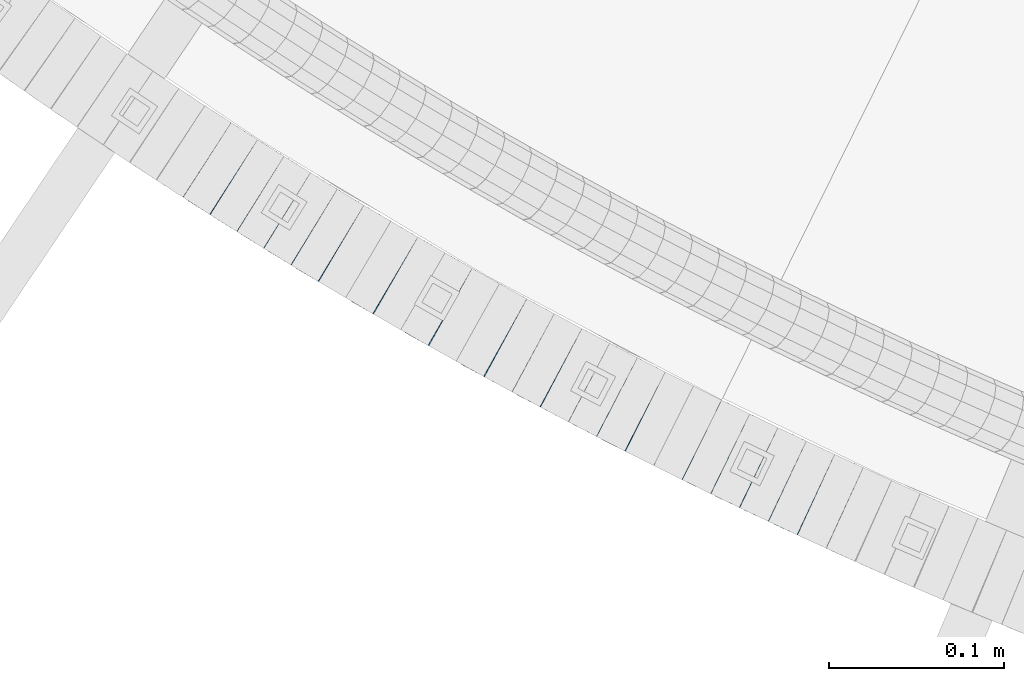
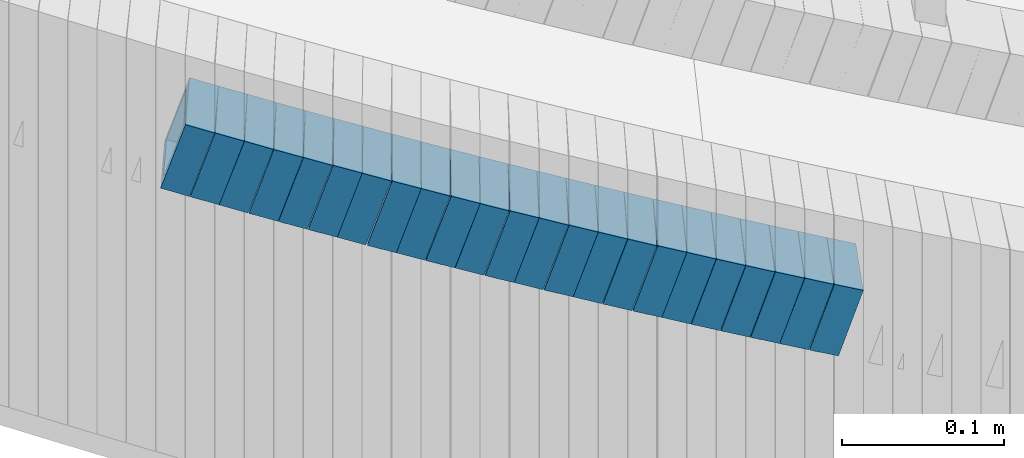
# One storey, part 650 of 975: 23 beams.
"""IFC2X3 building model written with IfcOpenShell, lengths in millimetres."""

from ifc_helpers import new_model, si_unit, frame, origin_with_axes, place, context, subcontext, project, spatial, faceted_brep, material, type_object, element, save


model = new_model("IFC2X3")

# Units and contexts
model_context = context("Model", 3, precision=1e-05, world=origin_with_axes())
body_context = subcontext(model_context, "Body", "Model", "MODEL_VIEW")
ifc_project = project(units=[si_unit("LENGTHUNIT", "METRE", prefix="MILLI"), si_unit("AREAUNIT", "SQUARE_METRE"), si_unit("VOLUMEUNIT", "CUBIC_METRE"), si_unit("MASSUNIT", "GRAM", prefix="KILO"), si_unit("TIMEUNIT", "SECOND"), si_unit("PLANEANGLEUNIT", "RADIAN"), si_unit("SOLIDANGLEUNIT", "STERADIAN"), si_unit("THERMODYNAMICTEMPERATUREUNIT", "DEGREE_CELSIUS"), si_unit("LUMINOUSINTENSITYUNIT", "LUMEN")], contexts=[model_context])

# Site, building, storey
site_placement = place(None, origin_with_axes())
site = spatial("IfcSite", under=ifc_project, at=site_placement, CompositionType="ELEMENT")
building_placement = place(site_placement, origin_with_axes())
building = spatial("IfcBuilding", under=site, at=building_placement, Name="Undefined", CompositionType="ELEMENT")
storey_placement = place(building_placement, origin_with_axes())
storey = spatial("IfcBuildingStorey", under=building, at=storey_placement, Name="Undefined", CompositionType="ELEMENT", Elevation=0.0)

# Beams
ifc_material = material()
beam_type = type_object("IfcBeamType", Name="HSS2X2X.188_TUBES", PredefinedType="NOTDEFINED")
beam_1_placement = place(storey_placement, frame((33173.8682936073, 994.158884126241, 3812.79161391269), z_axis=(0.540475947434613, 0.841359465534594, 2.42845999309793e-10), x_axis=(0.801887983873105, -0.515120094918474, -0.302699436952085)))
element("IfcBeam", 1, at=beam_1_placement, inside=storey, type_object=beam_type, material=ifc_material, Name="WALL", ObjectType="HSS2X2X.188_TUBES", context=body_context, shape_type="Brep", body=[
    faceted_brep([(0.0, 20.6374999999753, -20.6375000000298), (0.0, -20.6375000000153, -20.6375000000153), (18.8332159191086, -20.6374999999916, -20.6375000000153), (18.8332159190923, 20.6375000000062, -20.6375000000335), (0.0, -20.6374999999825, 20.6375000000335), (18.8332159191377, -20.6375000000062, 20.6375000000335), (0.0, 20.6375000000116, 20.6375000000189), (18.8332159191141, 20.6374999999916, 20.6375000000116), (0.0, 25.3999999999724, -25.4000000000342), (0.0, 25.400000000016, 25.4000000000196), (18.8332159191159, 25.3999999999905, 25.4000000000124), (18.8332159190886, 25.4000000000069, -25.4000000000415), (0.0, -25.399999999976, 25.4000000000378), (18.8332159191395, -25.4000000000069, 25.4000000000378), (0.0, -25.400000000016, -25.4000000000196), (18.8332159191104, -25.3999999999905, -25.400000000016)], [[[0, 1, 2, 3]], [[1, 4, 5, 2]], [[4, 6, 7, 5]], [[6, 0, 3, 7]], [[8, 9, 10, 11]], [[9, 12, 13, 10]], [[12, 14, 15, 13]], [[14, 8, 11, 15]], [[13, 15, 11, 10], [5, 7, 3, 2]], [[14, 12, 9, 8], [6, 4, 1, 0]]]),
])
beam_2_placement = place(storey_placement, frame((33189.0960442762, 984.291496128066, 3807.10498443343), z_axis=(0.532515895694051, 0.846420002618772, 1.78752088686452e-11), x_axis=(0.806265556906497, -0.507253164941174, -0.304351898964699)))
element("IfcBeam", 2, at=beam_2_placement, inside=storey, type_object=beam_type, material=ifc_material, Name="WALL", ObjectType="HSS2X2X.188_TUBES", context=body_context, shape_type="Brep", body=[
    faceted_brep([(0.0, 20.6374999999753, -20.6375000000298), (0.0, -20.6375000000153, -20.6375000000153), (18.7347271129966, -20.6375000000116, -20.6375000000262), (18.7347271130257, 20.6374999999989, -20.6374999999935), (0.0, -20.6374999999825, 20.6375000000335), (18.7347271129947, -20.6375000000116, 20.6374999999607), (0.0, 20.6375000000116, 20.6375000000189), (18.7347271130147, 20.6375000000007, 20.6374999999898), (0.0, 25.3999999999724, -25.4000000000342), (0.0, 25.400000000016, 25.4000000000196), (18.7347271130166, 25.4000000000015, 25.3999999999905), (18.7347271130257, 25.3999999999996, -25.3999999999869), (0.0, -25.399999999976, 25.4000000000378), (18.7347271129875, -25.4000000000106, 25.3999999999505), (0.0, -25.400000000016, -25.4000000000196), (18.7347271130002, -25.4000000000124, -25.4000000000233)], [[[0, 1, 2, 3]], [[1, 4, 5, 2]], [[4, 6, 7, 5]], [[6, 0, 3, 7]], [[8, 9, 10, 11]], [[9, 12, 13, 10]], [[12, 14, 15, 13]], [[14, 8, 11, 15]], [[13, 15, 11, 10], [5, 7, 3, 2]], [[14, 12, 9, 8], [6, 4, 1, 0]]]),
])
beam_3_placement = place(storey_placement, frame((33204.1567968813, 974.772256517738, 3801.4514456185), z_axis=(0.528482007968654, 0.848944501868891, -1.39170879265293e-11), x_axis=(0.807117420250336, -0.502443957155832, -0.310018612096163)))
element("IfcBeam", 3, at=beam_3_placement, inside=storey, type_object=beam_type, material=ifc_material, Name="WALL", ObjectType="HSS2X2X.188_TUBES", context=body_context, shape_type="Brep", body=[
    faceted_brep([(0.0, 20.6374999999753, -20.6375000000298), (0.0, -20.6375000000153, -20.6375000000153), (18.7112265765609, -20.6375000000062, -20.6374999999862), (18.7112265765645, 20.6374999999898, -20.6374999999789), (0.0, -20.6374999999825, 20.6375000000335), (18.7112265765209, -20.6374999999916, 20.6374999999607), (0.0, 20.6375000000116, 20.6375000000189), (18.7112265765245, 20.6375000000025, 20.6374999999716), (0.0, 25.3999999999724, -25.4000000000342), (0.0, 25.400000000016, 25.4000000000196), (18.7112265765172, 25.4000000000051, 25.3999999999614), (18.7112265765718, 25.3999999999887, -25.3999999999724), (0.0, -25.399999999976, 25.4000000000378), (18.7112265765136, -25.3999999999905, 25.3999999999542), (0.0, -25.400000000016, -25.4000000000196), (18.7112265765682, -25.4000000000069, -25.3999999999796)], [[[0, 1, 2, 3]], [[1, 4, 5, 2]], [[4, 6, 7, 5]], [[6, 0, 3, 7]], [[8, 9, 10, 11]], [[9, 12, 13, 10]], [[12, 14, 15, 13]], [[14, 8, 11, 15]], [[13, 15, 11, 10], [5, 7, 3, 2]], [[14, 12, 9, 8], [6, 4, 1, 0]]]),
])
beam_4_placement = place(storey_placement, frame((33219.5212045514, 965.154894635469, 3795.59040999408), z_axis=(0.523475864943619, 0.852040503040513, 2.1981122699799e-11), x_axis=(0.812108317148984, -0.49894236509154, -0.302550157055498)))
element("IfcBeam", 4, at=beam_4_placement, inside=storey, type_object=beam_type, material=ifc_material, Name="WALL", ObjectType="HSS2X2X.188_TUBES", context=body_context, shape_type="Brep", body=[
    faceted_brep([(0.0, 20.6374999999753, -20.6375000000298), (0.0, -20.6375000000153, -20.6375000000153), (18.8433011969464, -20.6374999999898, -20.6375000000226), (18.8433011969719, 20.6375000000007, -20.6374999999862), (0.0, -20.6374999999825, 20.6375000000335), (18.8433011969828, -20.6375000000044, 20.6375000000189), (0.0, 20.6375000000116, 20.6375000000189), (18.8433011970155, 20.6374999999862, 20.6375000000517), (0.0, 25.3999999999724, -25.4000000000342), (0.0, 25.400000000016, 25.4000000000196), (18.8433011970228, 25.3999999999833, 25.4000000000597), (18.8433011969719, 25.4000000000015, -25.3999999999869), (0.0, -25.399999999976, 25.4000000000378), (18.8433011969864, -25.4000000000051, 25.4000000000196), (0.0, -25.400000000016, -25.4000000000196), (18.8433011969391, -25.3999999999869, -25.4000000000269)], [[[0, 1, 2, 3]], [[1, 4, 5, 2]], [[4, 6, 7, 5]], [[6, 0, 3, 7]], [[8, 9, 10, 11]], [[9, 12, 13, 10]], [[12, 14, 15, 13]], [[14, 8, 11, 15]], [[13, 15, 11, 10], [5, 7, 3, 2]], [[14, 12, 9, 8], [6, 4, 1, 0]]]),
])
beam_5_placement = place(storey_placement, frame((33234.8751078169, 955.661924799427, 3789.91413765717), z_axis=(0.51780267961722, 0.855500078890251, -1.87630575965159e-10), x_axis=(0.814606580603603, -0.49305135176007, -0.30547746785135)))
element("IfcBeam", 5, at=beam_5_placement, inside=storey, type_object=beam_type, material=ifc_material, Name="WALL", ObjectType="HSS2X2X.188_TUBES", context=body_context, shape_type="Brep", body=[
    faceted_brep([(0.0, 20.6374999999753, -20.6375000000298), (0.0, -20.6375000000153, -20.6375000000153), (18.6593140280638, -20.6374999999971, -20.6375000000226), (18.6593140281293, 20.6374999999862, -20.6374999999862), (0.0, -20.6374999999825, 20.6375000000335), (18.6593140281693, -20.6375000000226, 20.6375000000407), (0.0, 20.6375000000116, 20.6375000000189), (18.6593140282275, 20.6374999999625, 20.6375000000771), (0.0, 25.3999999999724, -25.4000000000342), (0.0, 25.400000000016, 25.4000000000196), (18.6593140282457, 25.3999999999578, 25.4000000000888), (18.6593140281184, 25.3999999999887, -25.3999999999905), (0.0, -25.399999999976, 25.4000000000378), (18.6593140281766, -25.4000000000233, 25.4000000000487), (0.0, -25.400000000016, -25.4000000000196), (18.6593140280456, -25.3999999999905, -25.4000000000342)], [[[0, 1, 2, 3]], [[1, 4, 5, 2]], [[4, 6, 7, 5]], [[6, 0, 3, 7]], [[8, 9, 10, 11]], [[9, 12, 13, 10]], [[12, 14, 15, 13]], [[14, 8, 11, 15]], [[13, 15, 11, 10], [5, 7, 3, 2]], [[14, 12, 9, 8], [6, 4, 1, 0]]]),
])
beam_6_placement = place(storey_placement, frame((33250.3042446565, 946.229595588374, 3784.19899347823), z_axis=(0.508729312190843, 0.860926528176378, -2.37614585785195e-11), x_axis=(0.820286950044327, -0.484715016026192, -0.303612702016409)))
element("IfcBeam", 6, at=beam_6_placement, inside=storey, type_object=beam_type, material=ifc_material, Name="WALL", ObjectType="HSS2X2X.188_TUBES", context=body_context, shape_type="Brep", body=[
    faceted_brep([(0.0, 20.6374999999753, -20.6375000000298), (0.0, -20.6375000000153, -20.6375000000153), (18.767258723612, -20.6375000000025, -20.6374999999862), (18.7672587236229, 20.6374999999953, -20.637499999968), (0.0, -20.6374999999825, 20.6375000000335), (18.767258723612, -20.6375000000135, 20.6375000000153), (0.0, 20.6375000000116, 20.6375000000189), (18.7672587236266, 20.6374999999844, 20.6375000000371), (0.0, 25.3999999999724, -25.4000000000342), (0.0, 25.400000000016, 25.4000000000196), (18.7672587236302, 25.3999999999814, 25.4000000000342), (18.7672587236229, 25.399999999996, -25.3999999999687), (0.0, -25.399999999976, 25.4000000000378), (18.7672587236157, -25.4000000000142, 25.400000000016), (0.0, -25.400000000016, -25.4000000000196), (18.767258723612, -25.4000000000015, -25.3999999999905)], [[[0, 1, 2, 3]], [[1, 4, 5, 2]], [[4, 6, 7, 5]], [[6, 0, 3, 7]], [[8, 9, 10, 11]], [[9, 12, 13, 10]], [[12, 14, 15, 13]], [[14, 8, 11, 15]], [[13, 15, 11, 10], [5, 7, 3, 2]], [[14, 12, 9, 8], [6, 4, 1, 0]]]),
])
beam_7_placement = place(storey_placement, frame((33265.5987607468, 937.191926989541, 3778.53837842534), z_axis=(0.508729312190843, 0.860926528176378, -2.37614585785195e-11), x_axis=(0.818952007289953, -0.483926186171333, -0.308436470109203)))
element("IfcBeam", 7, at=beam_7_placement, inside=storey, type_object=beam_type, material=ifc_material, Name="WALL", ObjectType="HSS2X2X.188_TUBES", context=body_context, shape_type="Brep", body=[
    faceted_brep([(0.0, 20.6374999999753, -20.6375000000298), (0.0, -20.6375000000153, -20.6375000000153), (18.8047866246379, -20.6374999999916, -20.6375000000298), (18.8047866247143, 20.6374999999844, -20.6374999999643), (0.0, -20.6374999999825, 20.6375000000335), (18.8047866247107, -20.6375000000189, 20.6375000000407), (0.0, 20.6375000000116, 20.6375000000189), (18.8047866247907, 20.6374999999589, 20.6375000001026), (0.0, 25.3999999999724, -25.4000000000342), (0.0, 25.400000000016, 25.4000000000196), (18.8047866248016, 25.3999999999542, 25.4000000001142), (18.8047866247143, 25.3999999999851, -25.3999999999651), (0.0, -25.399999999976, 25.4000000000378), (18.8047866247107, -25.4000000000196, 25.4000000000415), (0.0, -25.400000000016, -25.4000000000196), (18.8047866246197, -25.3999999999887, -25.4000000000378)], [[[0, 1, 2, 3]], [[1, 4, 5, 2]], [[4, 6, 7, 5]], [[6, 0, 3, 7]], [[8, 9, 10, 11]], [[9, 12, 13, 10]], [[12, 14, 15, 13]], [[14, 8, 11, 15]], [[13, 15, 11, 10], [5, 7, 3, 2]], [[14, 12, 9, 8], [6, 4, 1, 0]]]),
])
for number, where, z_axis, x_axis, name in (
    (8, (33281.3248672153, 927.7896557307, 3772.70077400729), (0.497945444032448, 0.867208357182591, 2.00202521227766e-11), (0.826211457590163, -0.474405288764676, -0.303832600849288), "WALL"),
    (9, (33296.8248672153, 918.8896557307, 3767.00077400729), (0.497945444032448, 0.867208357182591, 2.00202521227766e-11), (0.826211457590163, -0.474405288764676, -0.303832600849288), "WALL"),
):
    element("IfcBeam", number, at=place(storey_placement, frame(where, z_axis=z_axis, x_axis=x_axis)), inside=storey, type_object=beam_type, material=ifc_material, Name=name, ObjectType="HSS2X2X.188_TUBES", context=body_context, shape_type="Brep", body=[
        faceted_brep([(0.0, 20.6374999999753, -20.6375000000298), (0.0, -20.6375000000153, -20.6375000000153), (18.7555325170906, -20.6374999999916, -20.6374999999971), (18.7555325171452, 20.637499999988, -20.6374999999571), (0.0, -20.6374999999825, 20.6375000000335), (18.7555325170615, -20.6374999999844, 20.6374999999716), (0.0, 20.6375000000116, 20.6375000000189), (18.7555325171015, 20.6374999999953, 20.637500000008), (0.0, 25.3999999999724, -25.4000000000342), (0.0, 25.400000000016, 25.4000000000196), (18.7555325171015, 25.399999999996, 25.4000000000051), (18.7555325171488, 25.3999999999851, -25.3999999999505), (0.0, -25.399999999976, 25.4000000000378), (18.755532517047, -25.3999999999814, 25.3999999999578), (0.0, -25.400000000016, -25.4000000000196), (18.7555325170979, -25.3999999999924, -25.3999999999978)], [[[0, 1, 2, 3]], [[1, 4, 5, 2]], [[4, 6, 7, 5]], [[6, 0, 3, 7]], [[8, 9, 10, 11]], [[9, 12, 13, 10]], [[12, 14, 15, 13]], [[14, 8, 11, 15]], [[13, 15, 11, 10], [5, 7, 3, 2]], [[14, 12, 9, 8], [6, 4, 1, 0]]]),
    ])
beam_8_placement = place(storey_placement, frame((33312.4425941713, 909.811293542964, 3761.34169177499), z_axis=(0.487068314604694, 0.873363874286167, 1.57364411279559e-10), x_axis=(0.830669042299038, -0.463257735166772, -0.308838490111177)))
element("IfcBeam", 10, at=beam_8_placement, inside=storey, type_object=beam_type, material=ifc_material, Name="WALL", ObjectType="HSS2X2X.188_TUBES", context=body_context, shape_type="Brep", body=[
    faceted_brep([(0.0, 20.6374999999753, -20.6375000000298), (0.0, -20.6375000000153, -20.6375000000153), (18.7771137292038, -20.637500000008, -20.6374999999862), (18.777113729182, 20.6375000000062, -20.6375000000189), (0.0, -20.6374999999825, 20.6375000000335), (18.7771137291729, -20.6374999999916, 20.6374999999753), (0.0, 20.6375000000116, 20.6375000000189), (18.7771137291529, 20.6375000000207, 20.6374999999389), (0.0, 25.3999999999724, -25.4000000000342), (0.0, 25.400000000016, 25.4000000000196), (18.7771137291475, 25.4000000000251, 25.3999999999287), (18.7771137291857, 25.4000000000051, -25.4000000000196), (0.0, -25.399999999976, 25.4000000000378), (18.7771137291711, -25.3999999999905, 25.3999999999724), (0.0, -25.400000000016, -25.4000000000196), (18.7771137292129, -25.4000000000124, -25.3999999999724)], [[[0, 1, 2, 3]], [[1, 4, 5, 2]], [[4, 6, 7, 5]], [[6, 0, 3, 7]], [[8, 9, 10, 11]], [[9, 12, 13, 10]], [[12, 14, 15, 13]], [[14, 8, 11, 15]], [[13, 15, 11, 10], [5, 7, 3, 2]], [[14, 12, 9, 8], [6, 4, 1, 0]]]),
])
beam_9_placement = place(storey_placement, frame((33328.1497127268, 901.051554348577, 3755.50220925443), z_axis=(0.487068314604694, 0.873363874286167, 1.57364411279559e-10), x_axis=(0.832026625199681, -0.464014849111359, -0.304009728072955)))
element("IfcBeam", 11, at=beam_9_placement, inside=storey, type_object=beam_type, material=ifc_material, Name="WALL", ObjectType="HSS2X2X.188_TUBES", context=body_context, shape_type="Brep", body=[
    faceted_brep([(0.0, 20.6374999999753, -20.6375000000298), (0.0, -20.6375000000153, -20.6375000000153), (18.7547327359644, -20.6374999999844, -20.6375000000553), (18.7547327359898, 20.6375000000171, -20.6375000000335), (0.0, -20.6374999999825, 20.6375000000335), (18.7547327360044, -20.6374999999953, 20.6374999999898), (0.0, 20.6375000000116, 20.6375000000189), (18.7547327360262, 20.6375000000062, 20.6375000000116), (0.0, 25.3999999999724, -25.4000000000342), (0.0, 25.400000000016, 25.4000000000196), (18.7547327360371, 25.4000000000033, 25.4000000000124), (18.7547327359898, 25.4000000000178, -25.4000000000342), (0.0, -25.399999999976, 25.4000000000378), (18.7547327360044, -25.399999999996, 25.3999999999869), (0.0, -25.400000000016, -25.4000000000196), (18.7547327359498, -25.3999999999814, -25.4000000000597)], [[[0, 1, 2, 3]], [[1, 4, 5, 2]], [[4, 6, 7, 5]], [[6, 0, 3, 7]], [[8, 9, 10, 11]], [[9, 12, 13, 10]], [[12, 14, 15, 13]], [[14, 8, 11, 15]], [[13, 15, 11, 10], [5, 7, 3, 2]], [[14, 12, 9, 8], [6, 4, 1, 0]]]),
])
beam_10_placement = place(storey_placement, frame((33343.9787129737, 892.115445935402, 3749.80329672255), z_axis=(0.476102697080729, 0.879389687131056, -2.74394551524893e-12), x_axis=(0.837729580038765, -0.45354786202099, -0.30414386001408)))
element("IfcBeam", 12, at=beam_10_placement, inside=storey, type_object=beam_type, material=ifc_material, Name="WALL", ObjectType="HSS2X2X.188_TUBES", context=body_context, shape_type="Brep", body=[
    faceted_brep([(0.0, 20.6374999999753, -20.6375000000298), (0.0, -20.6375000000153, -20.6375000000153), (18.7416648140024, -20.6375000000153, -20.6374999999825), (18.7416648139188, 20.6375000000189, -20.6375000000298), (0.0, -20.6374999999825, 20.6375000000335), (18.7416648140097, -20.6375000000189, 20.6375000000226), (0.0, 20.6375000000116, 20.6375000000189), (18.741664813926, 20.6375000000153, 20.6374999999753), (0.0, 25.3999999999724, -25.4000000000342), (0.0, 25.400000000016, 25.4000000000196), (18.7416648139224, 25.4000000000196, 25.3999999999687), (18.7416648139042, 25.4000000000233, -25.4000000000378), (0.0, -25.399999999976, 25.4000000000378), (18.7416648140133, -25.4000000000215, 25.4000000000269), (0.0, -25.400000000016, -25.4000000000196), (18.7416648140133, -25.4000000000196, -25.399999999976)], [[[0, 1, 2, 3]], [[1, 4, 5, 2]], [[4, 6, 7, 5]], [[6, 0, 3, 7]], [[8, 9, 10, 11]], [[9, 12, 13, 10]], [[12, 14, 15, 13]], [[14, 8, 11, 15]], [[13, 15, 11, 10], [5, 7, 3, 2]], [[14, 12, 9, 8], [6, 4, 1, 0]]]),
])
beam_11_placement = place(storey_placement, frame((33359.6509282113, 883.607013309172, 3744.1315202884), z_axis=(0.473767410843312, 0.880650010175906, 7.15508576831779e-11), x_axis=(0.837951650145135, -0.450796774078082, -0.307602504053268)))
element("IfcBeam", 13, at=beam_11_placement, inside=storey, type_object=beam_type, material=ifc_material, Name="WALL", ObjectType="HSS2X2X.188_TUBES", context=body_context, shape_type="Brep", body=[
    faceted_brep([(0.0, 20.6374999999753, -20.6375000000298), (0.0, -20.6375000000153, -20.6375000000153), (18.8565638439322, -20.6375000000116, -20.6374999999643), (18.8565638439395, 20.637499999988, -20.6374999999534), (0.0, -20.6374999999825, 20.6375000000335), (18.856563843914, -20.6374999999953, 20.6375000000116), (0.0, 20.6375000000116, 20.6375000000189), (18.8565638439177, 20.6375000000007, 20.6375000000226), (0.0, 25.3999999999724, -25.4000000000342), (0.0, 25.400000000016, 25.4000000000196), (18.8565638439177, 25.4000000000033, 25.4000000000233), (18.8565638439468, 25.3999999999851, -25.3999999999505), (0.0, -25.399999999976, 25.4000000000378), (18.8565638439104, -25.399999999996, 25.4000000000087), (0.0, -25.400000000016, -25.4000000000196), (18.8565638439395, -25.4000000000124, -25.3999999999614)], [[[0, 1, 2, 3]], [[1, 4, 5, 2]], [[4, 6, 7, 5]], [[6, 0, 3, 7]], [[8, 9, 10, 11]], [[9, 12, 13, 10]], [[12, 14, 15, 13]], [[14, 8, 11, 15]], [[13, 15, 11, 10], [5, 7, 3, 2]], [[14, 12, 9, 8], [6, 4, 1, 0]]]),
])
beam_12_placement = place(storey_placement, frame((33375.7117929588, 874.881483270046, 3738.30403451363), z_axis=(0.465053504492513, 0.885282575203665, 1.73736225406174e-10), x_axis=(0.843317584234268, -0.443008604123065, -0.304234825084524)))
element("IfcBeam", 14, at=beam_12_placement, inside=storey, type_object=beam_type, material=ifc_material, Name="WALL", ObjectType="HSS2X2X.188_TUBES", context=body_context, shape_type="Brep", body=[
    faceted_brep([(0.0, 20.6374999999753, -20.6375000000298), (0.0, -20.6375000000153, -20.6375000000153), (18.7416648140024, -20.6375000000153, -20.6374999999825), (18.7416648139188, 20.6375000000189, -20.6375000000298), (0.0, -20.6374999999825, 20.6375000000335), (18.7416648140097, -20.6375000000189, 20.6375000000226), (0.0, 20.6375000000116, 20.6375000000189), (18.741664813926, 20.6375000000153, 20.6374999999753), (0.0, 25.3999999999724, -25.4000000000342), (0.0, 25.400000000016, 25.4000000000196), (18.7416648139224, 25.4000000000196, 25.3999999999687), (18.7416648139042, 25.4000000000233, -25.4000000000378), (0.0, -25.399999999976, 25.4000000000378), (18.7416648140133, -25.4000000000215, 25.4000000000269), (0.0, -25.400000000016, -25.4000000000196), (18.7416648140133, -25.4000000000196, -25.399999999976)], [[[0, 1, 2, 3]], [[1, 4, 5, 2]], [[4, 6, 7, 5]], [[6, 0, 3, 7]], [[8, 9, 10, 11]], [[9, 12, 13, 10]], [[12, 14, 15, 13]], [[14, 8, 11, 15]], [[13, 15, 11, 10], [5, 7, 3, 2]], [[14, 12, 9, 8], [6, 4, 1, 0]]]),
])
beam_13_placement = place(storey_placement, frame((33391.4831603362, 866.573731464011, 3732.63219556766), z_axis=(0.46275653681341, 0.886485413098523, -2.18433342524804e-10), x_axis=(0.843480555132717, -0.440307460069283, -0.307684731048422)))
element("IfcBeam", 15, at=beam_13_placement, inside=storey, type_object=beam_type, material=ifc_material, Name="WALL", ObjectType="HSS2X2X.188_TUBES", context=body_context, shape_type="Brep", body=[
    faceted_brep([(0.0, 20.6374999999753, -20.6375000000298), (0.0, -20.6375000000153, -20.6375000000153), (18.8480768248774, -20.6374999999716, -20.6375000000735), (18.8480768249356, 20.6375000000153, -20.6375000000226), (0.0, -20.6374999999825, 20.6375000000335), (18.8480768249283, -20.6374999999935, 20.6374999999716), (0.0, 20.6375000000116, 20.6375000000189), (18.8480768249865, 20.6374999999935, 20.6375000000262), (0.0, 25.3999999999724, -25.4000000000342), (0.0, 25.400000000016, 25.4000000000196), (18.848076825001, 25.3999999999887, 25.4000000000378), (18.8480768249392, 25.4000000000142, -25.4000000000233), (0.0, -25.399999999976, 25.4000000000378), (18.8480768249283, -25.399999999996, 25.3999999999833), (0.0, -25.400000000016, -25.4000000000196), (18.8480768248664, -25.3999999999687, -25.4000000000779)], [[[0, 1, 2, 3]], [[1, 4, 5, 2]], [[4, 6, 7, 5]], [[6, 0, 3, 7]], [[8, 9, 10, 11]], [[9, 12, 13, 10]], [[12, 14, 15, 13]], [[14, 8, 11, 15]], [[13, 15, 11, 10], [5, 7, 3, 2]], [[14, 12, 9, 8], [6, 4, 1, 0]]]),
])
beam_14_placement = place(storey_placement, frame((33407.5697468045, 858.133580946775, 3726.79871465884), z_axis=(0.458358127885098, 0.888767588631397, -2.12935447052587e-11), x_axis=(0.846823544044339, -0.436726608022867, -0.303578252015895)))
element("IfcBeam", 16, at=beam_14_placement, inside=storey, type_object=beam_type, material=ifc_material, Name="WALL", ObjectType="HSS2X2X.188_TUBES", context=body_context, shape_type="Brep", body=[
    faceted_brep([(0.0, 20.6374999999753, -20.6375000000298), (0.0, -20.6375000000153, -20.6375000000153), (18.7771137292038, -20.637500000008, -20.6374999999862), (18.777113729182, 20.6375000000062, -20.6375000000189), (0.0, -20.6374999999825, 20.6375000000335), (18.7771137291729, -20.6374999999916, 20.6374999999753), (0.0, 20.6375000000116, 20.6375000000189), (18.7771137291529, 20.6375000000207, 20.6374999999389), (0.0, 25.3999999999724, -25.4000000000342), (0.0, 25.400000000016, 25.4000000000196), (18.7771137291475, 25.4000000000251, 25.3999999999287), (18.7771137291857, 25.4000000000051, -25.4000000000196), (0.0, -25.399999999976, 25.4000000000378), (18.7771137291711, -25.3999999999905, 25.3999999999724), (0.0, -25.400000000016, -25.4000000000196), (18.7771137292129, -25.4000000000124, -25.3999999999724)], [[[0, 1, 2, 3]], [[1, 4, 5, 2]], [[4, 6, 7, 5]], [[6, 0, 3, 7]], [[8, 9, 10, 11]], [[9, 12, 13, 10]], [[12, 14, 15, 13]], [[14, 8, 11, 15]], [[13, 15, 11, 10], [5, 7, 3, 2]], [[14, 12, 9, 8], [6, 4, 1, 0]]]),
])
beam_15_placement = place(storey_placement, frame((33423.7086882291, 849.704137383543, 3721.09888890575), z_axis=(0.447213595463116, 0.894427191018337, -1.29375166579848e-10), x_axis=(0.852209914200118, -0.426104957100095, -0.30359978207132)))
element("IfcBeam", 17, at=beam_15_placement, inside=storey, type_object=beam_type, material=ifc_material, Name="WALL", ObjectType="HSS2X2X.188_TUBES", context=body_context, shape_type="Brep", body=[
    faceted_brep([(0.0, 20.6374999999753, -20.6375000000298), (0.0, -20.6375000000153, -20.6375000000153), (18.767258723612, -20.6375000000025, -20.6374999999862), (18.7672587236229, 20.6374999999953, -20.637499999968), (0.0, -20.6374999999825, 20.6375000000335), (18.767258723612, -20.6375000000135, 20.6375000000153), (0.0, 20.6375000000116, 20.6375000000189), (18.7672587236266, 20.6374999999844, 20.6375000000371), (0.0, 25.3999999999724, -25.4000000000342), (0.0, 25.400000000016, 25.4000000000196), (18.7672587236302, 25.3999999999814, 25.4000000000342), (18.7672587236229, 25.399999999996, -25.3999999999687), (0.0, -25.399999999976, 25.4000000000378), (18.7672587236157, -25.4000000000142, 25.400000000016), (0.0, -25.400000000016, -25.4000000000196), (18.767258723612, -25.4000000000015, -25.3999999999905)], [[[0, 1, 2, 3]], [[1, 4, 5, 2]], [[4, 6, 7, 5]], [[6, 0, 3, 7]], [[8, 9, 10, 11]], [[9, 12, 13, 10]], [[12, 14, 15, 13]], [[14, 8, 11, 15]], [[13, 15, 11, 10], [5, 7, 3, 2]], [[14, 12, 9, 8], [6, 4, 1, 0]]]),
])
beam_16_placement = place(storey_placement, frame((33439.6785838098, 841.69758810927, 3715.42684924284), z_axis=(0.444987275598141, 0.895536891789358, -2.03050603886368e-10), x_axis=(0.85228142922637, -0.423493878112482, -0.30703306108155)))
element("IfcBeam", 18, at=beam_16_placement, inside=storey, type_object=beam_type, material=ifc_material, Name="WALL", ObjectType="HSS2X2X.188_TUBES", context=body_context, shape_type="Brep", body=[
    faceted_brep([(0.0, 20.6374999999753, -20.6375000000298), (0.0, -20.6375000000153, -20.6375000000153), (18.891267824034, -20.6375000000153, -20.6374999999971), (18.891267824034, 20.6375000000025, -20.637500000008), (0.0, -20.6374999999825, 20.6375000000335), (18.8912678240486, -20.6374999999989, 20.6375000000153), (0.0, 20.6375000000116, 20.6375000000189), (18.8912678240449, 20.6375000000189, 20.6375000000007), (0.0, 25.3999999999724, -25.4000000000342), (0.0, 25.400000000016, 25.4000000000196), (18.8912678240467, 25.4000000000215, 25.4000000000051), (18.8912678240304, 25.4000000000033, -25.4000000000124), (0.0, -25.399999999976, 25.4000000000378), (18.8912678240504, -25.3999999999996, 25.400000000016), (0.0, -25.400000000016, -25.4000000000196), (18.891267824034, -25.4000000000178, -25.3999999999978)], [[[0, 1, 2, 3]], [[1, 4, 5, 2]], [[4, 6, 7, 5]], [[6, 0, 3, 7]], [[8, 9, 10, 11]], [[9, 12, 13, 10]], [[12, 14, 15, 13]], [[14, 8, 11, 15]], [[13, 15, 11, 10], [5, 7, 3, 2]], [[14, 12, 9, 8], [6, 4, 1, 0]]]),
])
beam_17_placement = place(storey_placement, frame((33455.8594199452, 833.614191722764, 3709.63248011751), z_axis=(0.440509792900084, 0.897747805544032, -3.59500518243294e-11), x_axis=(0.85418653336067, -0.419135007176973, -0.307719372129932)))
element("IfcBeam", 19, at=beam_17_placement, inside=storey, type_object=beam_type, material=ifc_material, Name="WALL", ObjectType="HSS2X2X.188_TUBES", context=body_context, shape_type="Brep", body=[
    faceted_brep([(0.0, 20.6374999999753, -20.6375000000298), (0.0, -20.6375000000153, -20.6375000000153), (18.8480768248774, -20.6374999999716, -20.6375000000735), (18.8480768249356, 20.6375000000153, -20.6375000000226), (0.0, -20.6374999999825, 20.6375000000335), (18.8480768249283, -20.6374999999935, 20.6374999999716), (0.0, 20.6375000000116, 20.6375000000189), (18.8480768249865, 20.6374999999935, 20.6375000000262), (0.0, 25.3999999999724, -25.4000000000342), (0.0, 25.400000000016, 25.4000000000196), (18.848076825001, 25.3999999999887, 25.4000000000378), (18.8480768249392, 25.4000000000142, -25.4000000000233), (0.0, -25.399999999976, 25.4000000000378), (18.8480768249283, -25.399999999996, 25.3999999999833), (0.0, -25.400000000016, -25.4000000000196), (18.8480768248664, -25.3999999999687, -25.4000000000779)], [[[0, 1, 2, 3]], [[1, 4, 5, 2]], [[4, 6, 7, 5]], [[6, 0, 3, 7]], [[8, 9, 10, 11]], [[9, 12, 13, 10]], [[12, 14, 15, 13]], [[14, 8, 11, 15]], [[13, 15, 11, 10], [5, 7, 3, 2]], [[14, 12, 9, 8], [6, 4, 1, 0]]]),
])
beam_18_placement = place(storey_placement, frame((33472.1514600942, 825.577215277542, 3703.79871465884), z_axis=(0.435999194636003, 0.899947055263118, 1.40920292324154e-10), x_axis=(0.857475412684117, -0.41542287084696, -0.303578251888163)))
element("IfcBeam", 20, at=beam_18_placement, inside=storey, type_object=beam_type, material=ifc_material, Name="WALL", ObjectType="HSS2X2X.188_TUBES", context=body_context, shape_type="Brep", body=[
    faceted_brep([(0.0, 20.6374999999753, -20.6375000000298), (0.0, -20.6375000000153, -20.6375000000153), (18.7771137292038, -20.637500000008, -20.6374999999862), (18.777113729182, 20.6375000000062, -20.6375000000189), (0.0, -20.6374999999825, 20.6375000000335), (18.7771137291729, -20.6374999999916, 20.6374999999753), (0.0, 20.6375000000116, 20.6375000000189), (18.7771137291529, 20.6375000000207, 20.6374999999389), (0.0, 25.3999999999724, -25.4000000000342), (0.0, 25.400000000016, 25.4000000000196), (18.7771137291475, 25.4000000000251, 25.3999999999287), (18.7771137291857, 25.4000000000051, -25.4000000000196), (0.0, -25.399999999976, 25.4000000000378), (18.7771137291711, -25.3999999999905, 25.3999999999724), (0.0, -25.400000000016, -25.4000000000196), (18.7771137292129, -25.4000000000124, -25.3999999999724)], [[[0, 1, 2, 3]], [[1, 4, 5, 2]], [[4, 6, 7, 5]], [[6, 0, 3, 7]], [[8, 9, 10, 11]], [[9, 12, 13, 10]], [[12, 14, 15, 13]], [[14, 8, 11, 15]], [[13, 15, 11, 10], [5, 7, 3, 2]], [[14, 12, 9, 8], [6, 4, 1, 0]]]),
])
beam_19_placement = place(storey_placement, frame((33488.4137071331, 817.635729334599, 3698.09288927892), z_axis=(0.429284240916073, 0.903169441744522, -1.07634150481317e-11), x_axis=(0.860752861652545, -0.409123273834847, -0.302857487877736)))
element("IfcBeam", 21, at=beam_19_placement, inside=storey, type_object=beam_type, material=ifc_material, Name="WALL", ObjectType="HSS2X2X.188_TUBES", context=body_context, shape_type="Brep", body=[
    faceted_brep([(0.0, 20.6374999999753, -20.6375000000298), (0.0, -20.6375000000153, -20.6375000000153), (18.8225928075335, -20.6374999999935, -20.6375000000298), (18.8225928075699, 20.6374999999898, -20.6374999999825), (0.0, -20.6374999999825, 20.6375000000335), (18.8225928075772, -20.637500000008, 20.6375000000226), (0.0, 20.6375000000116, 20.6375000000189), (18.8225928076135, 20.6374999999753, 20.6375000000698), (0.0, 25.3999999999724, -25.4000000000342), (0.0, 25.400000000016, 25.4000000000196), (18.8225928076281, 25.3999999999705, 25.4000000000815), (18.8225928075663, 25.3999999999905, -25.3999999999796), (0.0, -25.399999999976, 25.4000000000378), (18.8225928075808, -25.4000000000087, 25.4000000000233), (0.0, -25.400000000016, -25.4000000000196), (18.8225928075226, -25.3999999999905, -25.4000000000378)], [[[0, 1, 2, 3]], [[1, 4, 5, 2]], [[4, 6, 7, 5]], [[6, 0, 3, 7]], [[8, 9, 10, 11]], [[9, 12, 13, 10]], [[12, 14, 15, 13]], [[14, 8, 11, 15]], [[13, 15, 11, 10], [5, 7, 3, 2]], [[14, 12, 9, 8], [6, 4, 1, 0]]]),
])
beam_20_placement = place(storey_placement, frame((33504.58706972, 809.904981469927, 3692.43755285078), z_axis=(0.424720210825697, 0.905324661387381, 1.0447547538206e-10), x_axis=(0.86121493282804, -0.404026757919322, -0.308336209938432)))
element("IfcBeam", 22, at=beam_20_placement, inside=storey, type_object=beam_type, material=ifc_material, Name="WALL", ObjectType="HSS2X2X.188_TUBES", context=body_context, shape_type="Brep", body=[
    faceted_brep([(0.0, 20.6374999999753, -20.6375000000298), (0.0, -20.6375000000153, -20.6375000000153), (18.8066477608099, -20.6374999999862, -20.6375000000116), (18.8066477608172, 20.6375000000062, -20.6374999999971), (0.0, -20.6374999999825, 20.6375000000335), (18.8066477608463, -20.6375000000062, 20.6375000000407), (0.0, 20.6375000000116, 20.6375000000189), (18.8066477608536, 20.6374999999844, 20.637500000048), (0.0, 25.3999999999724, -25.4000000000342), (0.0, 25.400000000016, 25.4000000000196), (18.8066477608591, 25.3999999999814, 25.400000000056), (18.8066477608154, 25.4000000000051, -25.4000000000015), (0.0, -25.399999999976, 25.4000000000378), (18.8066477608518, -25.4000000000087, 25.4000000000451), (0.0, -25.400000000016, -25.4000000000196), (18.8066477608081, -25.3999999999851, -25.4000000000196)], [[[0, 1, 2, 3]], [[1, 4, 5, 2]], [[4, 6, 7, 5]], [[6, 0, 3, 7]], [[8, 9, 10, 11]], [[9, 12, 13, 10]], [[12, 14, 15, 13]], [[14, 8, 11, 15]], [[13, 15, 11, 10], [5, 7, 3, 2]], [[14, 12, 9, 8], [6, 4, 1, 0]]]),
])
beam_21_placement = place(storey_placement, frame((33521.0618515555, 802.113874614074, 3686.5921650874), z_axis=(0.417997605365498, 0.908448128353353, -5.85609996051063e-11), x_axis=(0.865809540400412, -0.398378623184239, -0.302767753140023)))
element("IfcBeam", 23, at=beam_21_placement, inside=storey, type_object=beam_type, material=ifc_material, Name="WALL", ObjectType="HSS2X2X.188_TUBES", context=body_context, shape_type="Brep", body=[
    faceted_brep([(0.0, 20.6374999999753, -20.6375000000298), (0.0, -20.6375000000153, -20.6375000000153), (18.8332159191086, -20.6374999999916, -20.6375000000153), (18.8332159190923, 20.6375000000062, -20.6375000000335), (0.0, -20.6374999999825, 20.6375000000335), (18.8332159191377, -20.6375000000062, 20.6375000000335), (0.0, 20.6375000000116, 20.6375000000189), (18.8332159191141, 20.6374999999916, 20.6375000000116), (0.0, 25.3999999999724, -25.4000000000342), (0.0, 25.400000000016, 25.4000000000196), (18.8332159191159, 25.3999999999905, 25.4000000000124), (18.8332159190886, 25.4000000000069, -25.4000000000415), (0.0, -25.399999999976, 25.4000000000378), (18.8332159191395, -25.4000000000069, 25.4000000000378), (0.0, -25.400000000016, -25.4000000000196), (18.8332159191104, -25.3999999999905, -25.400000000016)], [[[0, 1, 2, 3]], [[1, 4, 5, 2]], [[4, 6, 7, 5]], [[6, 0, 3, 7]], [[8, 9, 10, 11]], [[9, 12, 13, 10]], [[12, 14, 15, 13]], [[14, 8, 11, 15]], [[13, 15, 11, 10], [5, 7, 3, 2]], [[14, 12, 9, 8], [6, 4, 1, 0]]]),
])

save(model, "model.ifc")
